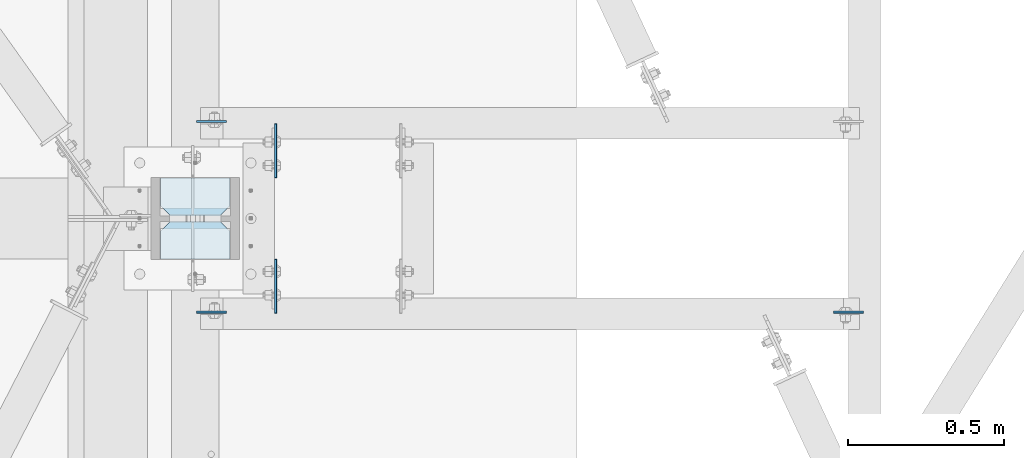
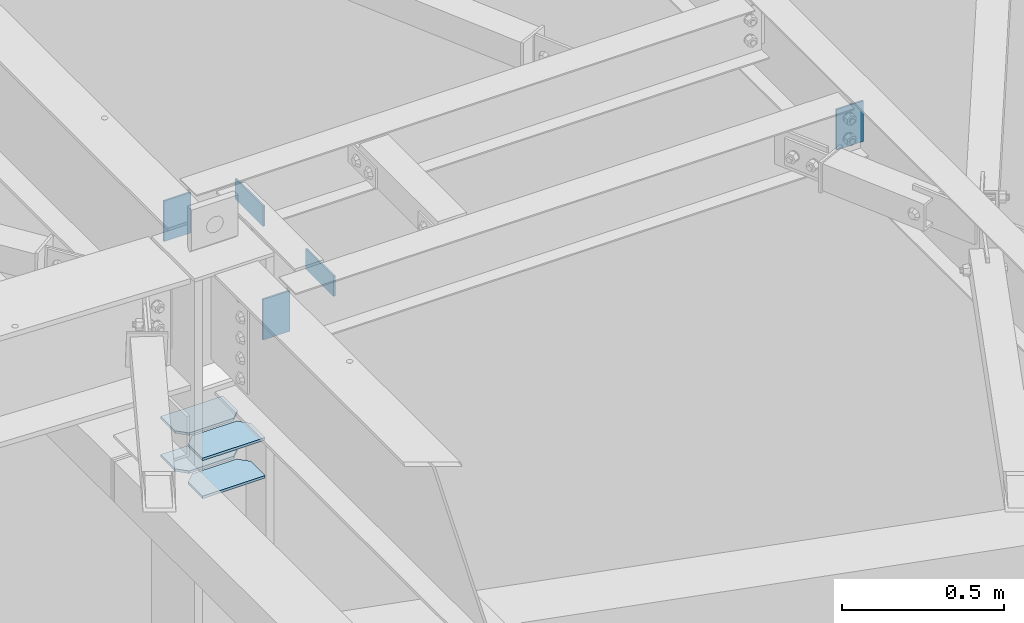
# One storey, part 1660 of 1763: 9 plates, 6 elements without a shape of their own.
"""IFC2X3 building model written with IfcOpenShell, lengths in millimetres."""

from ifc_helpers import new_model, si_unit, frame, origin_with_axes, place, context, subcontext, project, spatial, faceted_brep, material, type_object, element, aggregate, save


model = new_model("IFC2X3")

# Units and contexts
model_context = context("Model", 3, precision=1e-05, world=origin_with_axes())
body_context = subcontext(model_context, "Body", "Model", "MODEL_VIEW")
ifc_project = project(units=[si_unit("LENGTHUNIT", "METRE", prefix="MILLI"), si_unit("AREAUNIT", "SQUARE_METRE"), si_unit("VOLUMEUNIT", "CUBIC_METRE"), si_unit("MASSUNIT", "GRAM", prefix="KILO"), si_unit("TIMEUNIT", "SECOND"), si_unit("PLANEANGLEUNIT", "RADIAN"), si_unit("SOLIDANGLEUNIT", "STERADIAN"), si_unit("THERMODYNAMICTEMPERATUREUNIT", "DEGREE_CELSIUS"), si_unit("LUMINOUSINTENSITYUNIT", "LUMEN")], contexts=[model_context])

# Site, building, storey
site_placement = place(None, origin_with_axes())
site = spatial("IfcSite", under=ifc_project, at=site_placement, CompositionType="ELEMENT")
building_placement = place(site_placement, origin_with_axes())
building = spatial("IfcBuilding", under=site, at=building_placement, Name="Undefined", CompositionType="ELEMENT")
storey_placement = place(building_placement, origin_with_axes())
storey = spatial("IfcBuildingStorey", under=building, at=storey_placement, Name="Undefined", CompositionType="ELEMENT", Elevation=0.0)

# Assembly, plate
assembly_1_placement = place(storey_placement, origin_with_axes())
assembly_1 = element("IfcElementAssembly", 1, at=assembly_1_placement, inside=storey, Name="BEAM", AssemblyPlace="NOTDEFINED", PredefinedType="RIGID_FRAME")
ifc_material = material(Name="STEEL/A36")
plate_type_1 = type_object("IfcPlateType", PredefinedType="NOTDEFINED")
plate_1_placement = place(assembly_1_placement, frame((-39415.1146174484, 62899.13125, 12420.6), z_axis=(0.0, 1.0, 0.0), x_axis=(0.0, 0.0, -1.0)))
plate_1 = element("IfcPlate", 2, at=plate_1_placement, type_object=plate_type_1, material=ifc_material, Name="PLATE", context=body_context, shape_type="Brep", body=[
    faceted_brep([(1.81898940354586e-12, -3.17500000000291, 0.0), (0.0, -3.17500000000291, 171.449996948242), (0.0, 3.17500000000291, 171.449996948242), (-1.81898940354586e-12, 3.17499999997381, 0.0), (76.1999969482422, -3.17500000000291, 171.449996948242), (76.1999969482422, 3.17500000000291, 171.449996948242), (76.1999969482422, -3.17500000000291, 0.0), (76.1999969482422, 3.17500000000291, 0.0)], [[[0, 1, 2, 3]], [[1, 4, 5, 2]], [[4, 6, 7, 5]], [[6, 0, 3, 7]], [[5, 7, 3, 2]], [[6, 4, 1, 0]]]),
])
aggregate(assembly_1, [plate_1])

assembly_2_placement = place(storey_placement, origin_with_axes())
assembly_2 = element("IfcElementAssembly", 3, at=assembly_2_placement, inside=storey, Name="BEAM", AssemblyPlace="NOTDEFINED", PredefinedType="RIGID_FRAME")
plate_2_placement = place(assembly_2_placement, frame((-39415.1146174484, 63503.96875, 12420.6), z_axis=(0.0, -1.0, 0.0), x_axis=(0.0, 0.0, -1.0)))
plate_2 = element("IfcPlate", 4, at=plate_2_placement, type_object=plate_type_1, material=ifc_material, Name="PLATE", context=body_context, shape_type="Brep", body=[
    faceted_brep([(1.81898940354586e-12, -3.17500000000291, 0.0), (0.0, -3.17500000000291, 171.449996948242), (0.0, 3.17500000000291, 171.449996948242), (-1.81898940354586e-12, 3.17499999997381, 0.0), (76.1999969482422, -3.17500000000291, 171.449996948242), (76.1999969482422, 3.17500000000291, 171.449996948242), (76.1999969482422, -3.17500000000291, 0.0), (76.1999969482422, 3.17500000000291, 0.0)], [[[0, 1, 2, 3]], [[1, 4, 5, 2]], [[4, 6, 7, 5]], [[6, 0, 3, 7]], [[5, 7, 3, 2]], [[6, 4, 1, 0]]]),
])
aggregate(assembly_2, [plate_2])

# Assembly, plates
assembly_3_placement = place(storey_placement, origin_with_axes())
assembly_3 = element("IfcElementAssembly", 5, at=assembly_3_placement, inside=storey, Name="COLUMN", AssemblyPlace="NOTDEFINED", PredefinedType="RIGID_FRAME")
plate_type_2 = type_object("IfcPlateType", PredefinedType="NOTDEFINED")
plate_3_placement = place(assembly_3_placement, frame((-39561.1646174484, 63072.16875, 11612.5625), z_axis=(-1.0, 0.0, 0.0), x_axis=(0.0, 1.0, 0.0)))
plate_3 = element("IfcPlate", 6, at=plate_3_placement, type_object=plate_type_2, material=ifc_material, Name="PLATE", context=body_context, shape_type="Brep", body=[
    faceted_brep([(0.0, -4.76249999999982, 0.0), (0.0, -4.76250000000073, 222.25), (0.0, 4.76250000000073, 222.25), (0.0, 4.76249999999982, 0.0), (88.9000015258789, -4.76250000000073, 222.25), (88.9000015258789, 4.76250000000073, 222.25), (120.650001525879, -4.76250000000073, 190.5), (120.650001525879, 4.76250000000073, 190.5), (120.650001525879, -4.76249999999709, 31.75), (120.650001525879, 4.76249999999709, 31.75), (88.9000015258789, -4.76249999999709, 0.0), (88.9000015258789, 4.76249999999709, 0.0)], [[[0, 1, 2, 3]], [[1, 4, 5, 2]], [[4, 6, 7, 5]], [[6, 8, 9, 7]], [[8, 10, 11, 9]], [[10, 0, 3, 11]], [[5, 7, 9, 11, 3, 2]], [[10, 8, 6, 4, 1, 0]]]),
])
plate_4_placement = place(assembly_3_placement, frame((-39561.1646174484, 63210.28125, 11612.5625), z_axis=(-1.0, 0.0, 0.0), x_axis=(0.0, 1.0, 0.0)))
plate_4 = element("IfcPlate", 7, at=plate_4_placement, type_object=plate_type_2, material=ifc_material, Name="PLATE", context=body_context, shape_type="Brep", body=[
    faceted_brep([(0.0, -4.76250000000073, 31.75), (0.0, -4.76250000000073, 190.5), (0.0, 4.76250000000073, 190.5), (0.0, 4.76250000000073, 31.75), (31.75, -4.76250000000073, 222.25), (31.75, 4.76250000000073, 222.25), (120.650001525879, -4.76250000000073, 222.25), (120.650001525879, 4.76250000000073, 222.25), (120.650001525879, -4.76249999999709, 0.0), (120.650001525879, 4.76249999999709, 0.0), (31.75, -4.76250000000073, 0.0), (31.75, 4.76250000000073, 0.0)], [[[0, 1, 2, 3]], [[1, 4, 5, 2]], [[4, 6, 7, 5]], [[6, 8, 9, 7]], [[8, 10, 11, 9]], [[10, 0, 3, 11]], [[5, 7, 9, 11, 3, 2]], [[10, 8, 6, 4, 1, 0]]]),
])
plate_5_placement = place(assembly_3_placement, frame((-39561.1646174484, 63072.16875, 11755.4375), z_axis=(-1.0, 0.0, 0.0), x_axis=(0.0, 1.0, 0.0)))
plate_5 = element("IfcPlate", 8, at=plate_5_placement, type_object=plate_type_2, material=ifc_material, Name="PLATE", context=body_context, shape_type="Brep", body=[
    faceted_brep([(0.0, -4.76249999999982, 0.0), (0.0, -4.76250000000073, 222.25), (0.0, 4.76250000000073, 222.25), (0.0, 4.76249999999982, 0.0), (88.9000015258789, -4.76250000000073, 222.25), (88.9000015258789, 4.76250000000073, 222.25), (120.650001525879, -4.76250000000073, 190.5), (120.650001525879, 4.76250000000073, 190.5), (120.650001525879, -4.76249999999709, 31.75), (120.650001525879, 4.76249999999709, 31.75), (88.9000015258789, -4.76249999999709, 0.0), (88.9000015258789, 4.76249999999709, 0.0)], [[[0, 1, 2, 3]], [[1, 4, 5, 2]], [[4, 6, 7, 5]], [[6, 8, 9, 7]], [[8, 10, 11, 9]], [[10, 0, 3, 11]], [[5, 7, 9, 11, 3, 2]], [[10, 8, 6, 4, 1, 0]]]),
])
plate_6_placement = place(assembly_3_placement, frame((-39561.1646174484, 63210.28125, 11755.4375), z_axis=(-1.0, 0.0, 0.0), x_axis=(0.0, 1.0, 0.0)))
plate_6 = element("IfcPlate", 9, at=plate_6_placement, type_object=plate_type_2, material=ifc_material, Name="PLATE", context=body_context, shape_type="Brep", body=[
    faceted_brep([(0.0, -4.76250000000073, 31.75), (0.0, -4.76250000000073, 190.5), (0.0, 4.76250000000073, 190.5), (0.0, 4.76250000000073, 31.75), (31.75, -4.76250000000073, 222.25), (31.75, 4.76250000000073, 222.25), (120.650001525879, -4.76250000000073, 222.25), (120.650001525879, 4.76250000000073, 222.25), (120.650001525879, -4.76249999999709, 0.0), (120.650001525879, 4.76249999999709, 0.0), (31.75, -4.76250000000073, 0.0), (31.75, 4.76250000000073, 0.0)], [[[0, 1, 2, 3]], [[1, 4, 5, 2]], [[4, 6, 7, 5]], [[6, 8, 9, 7]], [[8, 10, 11, 9]], [[10, 0, 3, 11]], [[5, 7, 9, 11, 3, 2]], [[10, 8, 6, 4, 1, 0]]]),
])
aggregate(assembly_3, [plate_3, plate_4, plate_5, plate_6])

# Assembly, plate
assembly_4_placement = place(storey_placement, origin_with_axes())
assembly_4 = element("IfcElementAssembly", 10, at=assembly_4_placement, inside=storey, Name="BEAM", AssemblyPlace="NOTDEFINED", PredefinedType="RIGID_FRAME")
plate_type_3 = type_object("IfcPlateType", PredefinedType="NOTDEFINED")
plate_7_placement = place(assembly_4_placement, frame((-39668.3208674484, 63511.90625, 12420.6), z_axis=(1.0, 0.0, 0.0), x_axis=(0.0, 0.0, -1.0)))
plate_7 = element("IfcPlate", 11, at=plate_7_placement, type_object=plate_type_3, material=ifc_material, Name="PLATE", context=body_context, shape_type="Brep", body=[
    faceted_brep([(1.81898940354586e-12, -3.17500000000291, 0.0), (0.0, -3.17499999999927, 95.25), (0.0, 3.17499999999927, 95.25), (-1.81898940354586e-12, 3.17499999997381, 0.0), (152.399993896484, -3.17500000000291, 95.25), (152.399993896484, 3.17500000000291, 95.25), (152.399993896484, -3.17500000000291, 0.0), (152.399993896484, 3.17500000000291, 0.0)], [[[0, 1, 2, 3]], [[1, 4, 5, 2]], [[4, 6, 7, 5]], [[6, 0, 3, 7]], [[5, 7, 3, 2]], [[6, 4, 1, 0]]]),
])
aggregate(assembly_4, [plate_7])

assembly_5_placement = place(storey_placement, origin_with_axes())
assembly_5 = element("IfcElementAssembly", 12, at=assembly_5_placement, inside=storey, Name="BEAM", AssemblyPlace="NOTDEFINED", PredefinedType="RIGID_FRAME")
plate_8_placement = place(assembly_5_placement, frame((-39668.3208674484, 62902.30625, 12420.6), z_axis=(1.0, 0.0, 0.0), x_axis=(0.0, 0.0, -1.0)))
plate_8 = element("IfcPlate", 13, at=plate_8_placement, type_object=plate_type_3, material=ifc_material, Name="PLATE", context=body_context, shape_type="Brep", body=[
    faceted_brep([(1.81898940354586e-12, -3.17500000000291, 0.0), (0.0, -3.17499999999927, 95.25), (0.0, 3.17499999999927, 95.25), (-1.81898940354586e-12, 3.17499999997381, 0.0), (152.399993896484, -3.17500000000291, 95.25), (152.399993896484, 3.17500000000291, 95.25), (152.399993896484, -3.17500000000291, 0.0), (152.399993896484, 3.17500000000291, 0.0)], [[[0, 1, 2, 3]], [[1, 4, 5, 2]], [[4, 6, 7, 5]], [[6, 0, 3, 7]], [[5, 7, 3, 2]], [[6, 4, 1, 0]]]),
])
aggregate(assembly_5, [plate_8])

assembly_6_placement = place(storey_placement, origin_with_axes())
assembly_6 = element("IfcElementAssembly", 14, at=assembly_6_placement, inside=storey, Name="BEAM", AssemblyPlace="NOTDEFINED", PredefinedType="RIGID_FRAME")
plate_9_placement = place(assembly_6_placement, frame((-37535.5146174484, 62902.30625, 12420.6), z_axis=(-1.0, 0.0, 0.0), x_axis=(0.0, 0.0, -1.0)))
plate_9 = element("IfcPlate", 15, at=plate_9_placement, type_object=plate_type_3, material=ifc_material, Name="PLATE", context=body_context, shape_type="Brep", body=[
    faceted_brep([(1.81898940354586e-12, -3.17500000000291, 0.0), (0.0, -3.17499999999927, 95.25), (0.0, 3.17499999999927, 95.25), (-1.81898940354586e-12, 3.17499999997381, 0.0), (152.399993896484, -3.17500000000291, 95.25), (152.399993896484, 3.17500000000291, 95.25), (152.399993896484, -3.17500000000291, 0.0), (152.399993896484, 3.17500000000291, 0.0)], [[[0, 1, 2, 3]], [[1, 4, 5, 2]], [[4, 6, 7, 5]], [[6, 0, 3, 7]], [[5, 7, 3, 2]], [[6, 4, 1, 0]]]),
])
aggregate(assembly_6, [plate_9])

save(model, "model.ifc")
